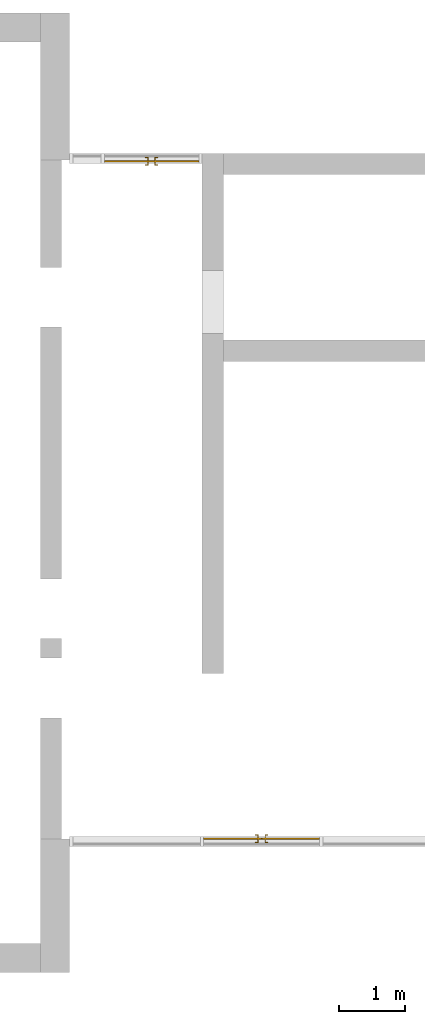
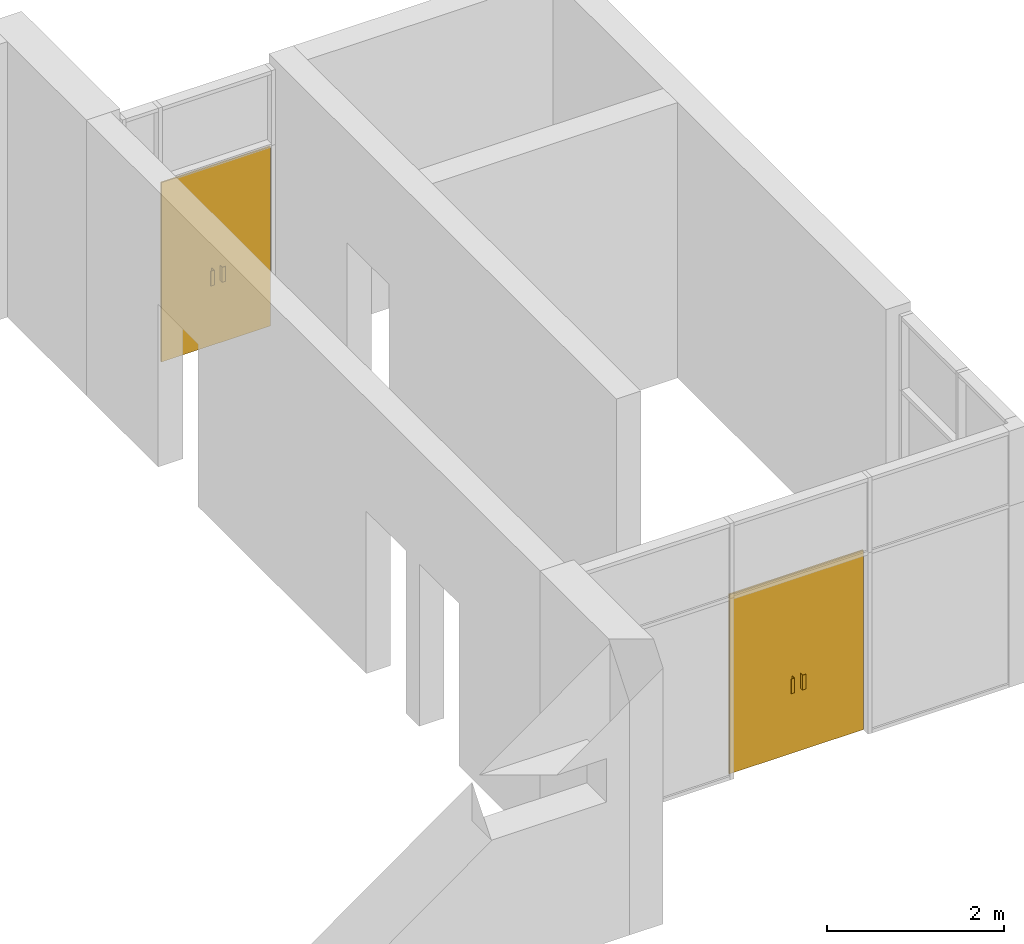
# One storey, part 4 of 4: 2 doors, 2 elements without a shape of their own.
"""IFC2X3 building model written with IfcOpenShell, lengths in millimetres."""

from ifc_helpers import new_model, entity, si_unit, converted_unit, derived_unit, direction, frame, origin, origin_2d_with_axis, place, context, subcontext, project, spatial, polyline, rectangle, outline, extrude, source, transform, mapped, material, material_list, type_object, type_shapes, element, aggregate, save


model = new_model("IFC2X3")

# Units and contexts
model_context = context("Model", 3, precision=0.01, world=origin(), true_north=direction((6.12303176911189e-17, 1.0)))
body_context = subcontext(model_context, "Body", "Model", "MODEL_VIEW")
ifc_project = project(units=[si_unit("LENGTHUNIT", "METRE", prefix="MILLI"), si_unit("AREAUNIT", "SQUARE_METRE"), si_unit("VOLUMEUNIT", "CUBIC_METRE"), converted_unit("PLANEANGLEUNIT", "DEGREE", entity("IfcRatioMeasure", 0.0174532925199433), si_unit("PLANEANGLEUNIT", "RADIAN"), dimensions=[0, 0, 0, 0, 0, 0, 0]), si_unit("MASSUNIT", "GRAM", prefix="KILO"), derived_unit("MASSDENSITYUNIT", [(si_unit("MASSUNIT", "GRAM", prefix="KILO"), 1), (si_unit("LENGTHUNIT", "METRE"), -3)]), si_unit("TIMEUNIT", "SECOND"), si_unit("FREQUENCYUNIT", "HERTZ"), si_unit("THERMODYNAMICTEMPERATUREUNIT", "DEGREE_CELSIUS"), derived_unit("THERMALTRANSMITTANCEUNIT", [(si_unit("MASSUNIT", "GRAM", prefix="KILO"), 1), (si_unit("THERMODYNAMICTEMPERATUREUNIT", "KELVIN"), -1), (si_unit("TIMEUNIT", "SECOND"), -3)]), derived_unit("VOLUMETRICFLOWRATEUNIT", [(si_unit("LENGTHUNIT", "METRE"), 3), (si_unit("TIMEUNIT", "SECOND"), -1)]), si_unit("ELECTRICCURRENTUNIT", "AMPERE"), si_unit("ELECTRICVOLTAGEUNIT", "VOLT"), si_unit("POWERUNIT", "WATT"), si_unit("FORCEUNIT", "NEWTON", prefix="KILO"), si_unit("ILLUMINANCEUNIT", "LUX"), si_unit("LUMINOUSFLUXUNIT", "LUMEN"), si_unit("LUMINOUSINTENSITYUNIT", "CANDELA"), derived_unit("USERDEFINED", [(si_unit("MASSUNIT", "GRAM", prefix="KILO"), -1), (si_unit("LENGTHUNIT", "METRE"), -2), (si_unit("TIMEUNIT", "SECOND"), 3), (si_unit("LUMINOUSFLUXUNIT", "LUMEN"), 1)]), derived_unit("LINEARVELOCITYUNIT", [(si_unit("LENGTHUNIT", "METRE"), 1), (si_unit("TIMEUNIT", "SECOND"), -1)]), si_unit("PRESSUREUNIT", "PASCAL"), derived_unit("USERDEFINED", [(si_unit("LENGTHUNIT", "METRE"), -2), (si_unit("MASSUNIT", "GRAM", prefix="KILO"), 1), (si_unit("TIMEUNIT", "SECOND"), -2)])], contexts=[model_context])

# Site, building, storey
site_placement = place(None, origin())
site = spatial("IfcSite", under=ifc_project, at=site_placement, CompositionType="ELEMENT")
building_placement = place(site_placement, origin())
building = spatial("IfcBuilding", under=site, at=building_placement, CompositionType="ELEMENT")
storey_placement = place(building_placement, origin())
storey = spatial("IfcBuildingStorey", under=building, at=storey_placement, Name="00 Ground level", CompositionType="ELEMENT", Elevation=0.0)

# Curtain wall, door
curtain_wall_type = type_object("IfcCurtainWallType", Name="Curtain Wall", PredefinedType="NOTDEFINED")
curtain_wall_1_placement = place(storey_placement, origin())
curtain_wall_1 = element("IfcCurtainWall", 1, at=curtain_wall_1_placement, inside=storey, type_object=curtain_wall_type, Name="Curtain Wall", ObjectType="Curtain Wall")
ifc_material_1 = material(Name="Glass")
ifc_material_2 = material(Name="Aluminum")
ifc_material_list_1 = material_list([ifc_material_1, ifc_material_2])
ifc_material_list_2 = material_list([ifc_material_1, ifc_material_2])
door_style_1 = type_object("IfcDoorStyle", Name="M_Door-Curtain-Wall-Double-Glass", ConstructionType="NOTDEFINED", OperationType="NOTDEFINED", ParameterTakesPrecedence=False, Sizeable=False, material=ifc_material_list_2)
shared_shape_1 = source(origin(), body_context, "Body", "SweptSolid", [
    extrude(rectangle(XDim=19.05, YDim=873.435600052848, at=origin_2d_with_axis()), frame((-438.282199973576, 41.2749999999964, 0.0), z_axis=(0.0, 0.0, 1.0), x_axis=(0.0, 1.0, 0.0)), (0.0, 0.0, 1.0), 2475.0),
    extrude(rectangle(XDim=19.05, YDim=873.389399947153, at=origin_2d_with_axis()), frame((438.305300026424, 41.2749999999965, 0.0), z_axis=(0.0, 0.0, 1.0), x_axis=(0.0, 1.0, 0.0)), (0.0, 0.0, 1.0), 2475.0),
    extrude(outline(polyline([(-19.0500000000001, -16.933333333333), (31.7500000000002, -16.933333333333), (31.7500000000002, -10.583333333333), (-12.7000000000001, -10.583333333333), (-12.7000000000001, 27.516666666666), (-19.0500000000001, 27.516666666666), (-19.0500000000001, -16.933333333333)])), frame((67.7564333861808, 82.549999999998, 863.599999999999), z_axis=(0.0, 0.0, 1.0), x_axis=(0.0, -1.0, 0.0)), (0.0, 0.0, 1.0), 203.199999999999),
    extrude(outline(polyline([(-16.933333333333, -19.05), (27.516666666666, -19.05), (27.516666666666, -12.7), (-10.583333333333, -12.7), (-10.583333333333, 31.75), (-16.933333333333, 31.75), (-16.933333333333, -19.05)])), frame((-67.7102332804856, 82.5499999999981, 863.599999999999), z_axis=(0.0, 0.0, 1.0), x_axis=(-1.0, 0.0, 0.0)), (0.0, 0.0, 1.0), 203.199999999999),
    extrude(outline(polyline([(-19.0500000000001, -16.933333333333), (31.7500000000002, -16.933333333333), (31.7500000000002, -10.583333333333), (-12.7000000000001, -10.583333333333), (-12.7000000000001, 27.5166666666661), (-19.0500000000001, 27.5166666666661), (-19.0500000000001, -16.933333333333)])), frame((-67.7102332804857, 0.0, 863.599999999999), z_axis=(0.0, 0.0, 1.0), x_axis=(0.0, 1.0, 0.0)), (0.0, 0.0, 1.0), 203.199999999999),
    extrude(outline(polyline([(-16.933333333333, -19.0500000000002), (27.5166666666661, -19.0500000000002), (27.5166666666661, -12.7000000000005), (-10.583333333333, -12.7000000000005), (-10.583333333333, 31.7500000000007), (-16.933333333333, 31.7500000000007), (-16.933333333333, -19.0500000000002)])), frame((67.7564333861805, 0.0, 863.599999999999)), (0.0, 0.0, 1.0), 203.199999999999),
])
type_shapes(door_style_1, [shared_shape_1])
door_1_placement = place(curtain_wall_1_placement, frame((31843.4900708517, -74100.8241905963, 0.0)))
door_1 = element("IfcDoor", 2, at=door_1_placement, type_object=door_style_1, material=ifc_material_list_1, OverallHeight=2476.85530434783, OverallWidth=1750.00000000001, context=body_context, shape_type="MappedRepresentation", body=[
    mapped(shared_shape_1, transform((0.0, 0.0, 0.0), scale=1.0)),
])
aggregate(curtain_wall_1, [door_1])

curtain_wall_2_placement = place(storey_placement, origin())
curtain_wall_2 = element("IfcCurtainWall", 3, at=curtain_wall_2_placement, inside=storey, type_object=curtain_wall_type, Name="Curtain Wall", ObjectType="Curtain Wall")
ifc_material_list_3 = material_list([ifc_material_1, ifc_material_2])
ifc_material_list_4 = material_list([ifc_material_1, ifc_material_2])
door_style_2 = type_object("IfcDoorStyle", Name="M_Door-Curtain-Wall-Double-Glass", ConstructionType="NOTDEFINED", OperationType="NOTDEFINED", ParameterTakesPrecedence=False, Sizeable=False, material=ifc_material_list_4)
shared_shape_2 = source(origin(), body_context, "Body", "SweptSolid", [
    extrude(rectangle(XDim=19.05, YDim=710.935600052848, at=origin_2d_with_axis()), frame((-357.032199973576, 41.2749999999964, 0.0), z_axis=(0.0, 0.0, 1.0), x_axis=(0.0, 1.0, 0.0)), (0.0, 0.0, 1.0), 2475.0),
    extrude(rectangle(XDim=19.05, YDim=710.889399947153, at=origin_2d_with_axis()), frame((357.055300026424, 41.2749999999965, 0.0), z_axis=(0.0, 0.0, 1.0), x_axis=(0.0, 1.0, 0.0)), (0.0, 0.0, 1.0), 2475.0),
    extrude(outline(polyline([(-19.0500000000001, -16.933333333333), (31.7500000000002, -16.933333333333), (31.7500000000002, -10.583333333333), (-12.7000000000001, -10.583333333333), (-12.7000000000001, 27.516666666666), (-19.0500000000001, 27.516666666666), (-19.0500000000001, -16.933333333333)])), frame((67.7564333861808, 82.549999999998, 863.599999999999), z_axis=(0.0, 0.0, 1.0), x_axis=(0.0, -1.0, 0.0)), (0.0, 0.0, 1.0), 203.199999999999),
    extrude(outline(polyline([(-16.933333333333, -19.05), (27.516666666666, -19.05), (27.516666666666, -12.7), (-10.583333333333, -12.7), (-10.583333333333, 31.75), (-16.933333333333, 31.75), (-16.933333333333, -19.05)])), frame((-67.7102332804856, 82.5499999999981, 863.599999999999), z_axis=(0.0, 0.0, 1.0), x_axis=(-1.0, 0.0, 0.0)), (0.0, 0.0, 1.0), 203.199999999999),
    extrude(outline(polyline([(-19.0500000000001, -16.933333333333), (31.7500000000002, -16.933333333333), (31.7500000000002, -10.583333333333), (-12.7000000000001, -10.583333333333), (-12.7000000000001, 27.5166666666661), (-19.0500000000001, 27.5166666666661), (-19.0500000000001, -16.933333333333)])), frame((-67.7102332804857, 0.0, 863.599999999999), z_axis=(0.0, 0.0, 1.0), x_axis=(0.0, 1.0, 0.0)), (0.0, 0.0, 1.0), 203.199999999999),
    extrude(outline(polyline([(-16.933333333333, -19.0500000000002), (27.5166666666661, -19.0500000000002), (27.5166666666661, -12.7000000000005), (-10.583333333333, -12.7000000000005), (-10.583333333333, 31.7500000000007), (-16.933333333333, 31.7500000000007), (-16.933333333333, -19.0500000000002)])), frame((67.7564333861805, 0.0, 863.599999999999)), (0.0, 0.0, 1.0), 203.199999999999),
])
type_shapes(door_style_2, [shared_shape_2])
door_2_placement = place(curtain_wall_2_placement, frame((30180.9900708518, -63780.8241905964, 0.0), z_axis=(0.0, 0.0, 1.0), x_axis=(-1.0, 0.0, 0.0)))
door_2 = element("IfcDoor", 4, at=door_2_placement, type_object=door_style_2, material=ifc_material_list_3, OverallHeight=2476.85530434783, OverallWidth=1425.00000000001, context=body_context, shape_type="MappedRepresentation", body=[
    mapped(shared_shape_2, transform((0.0, 0.0, 0.0), scale=1.0)),
])
aggregate(curtain_wall_2, [door_2])

save(model, "model.ifc")
